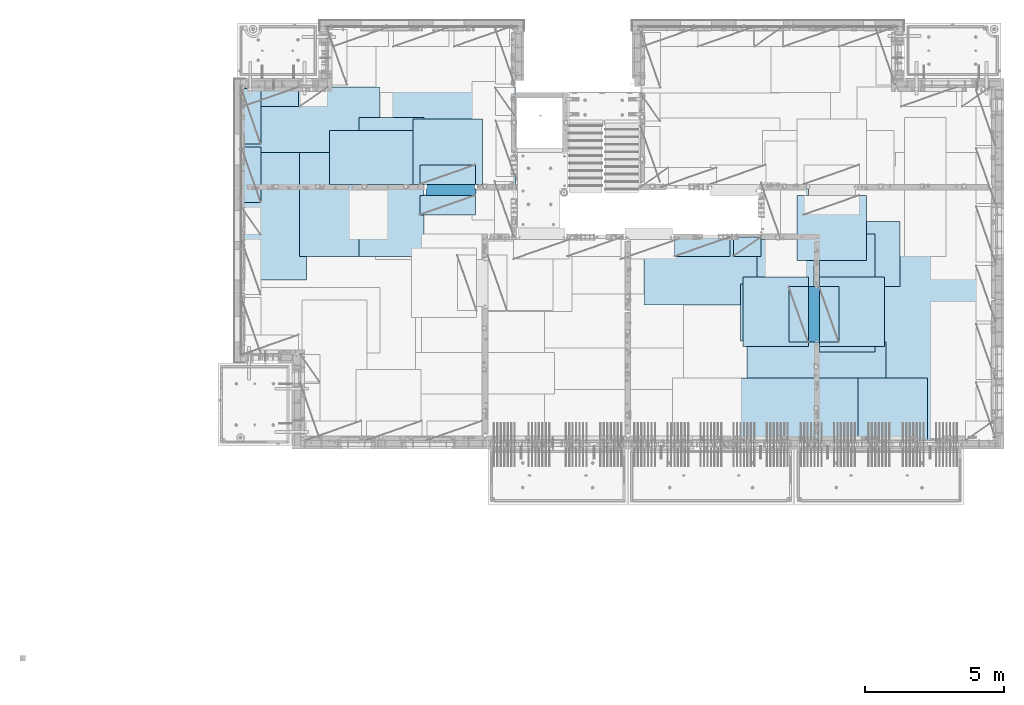
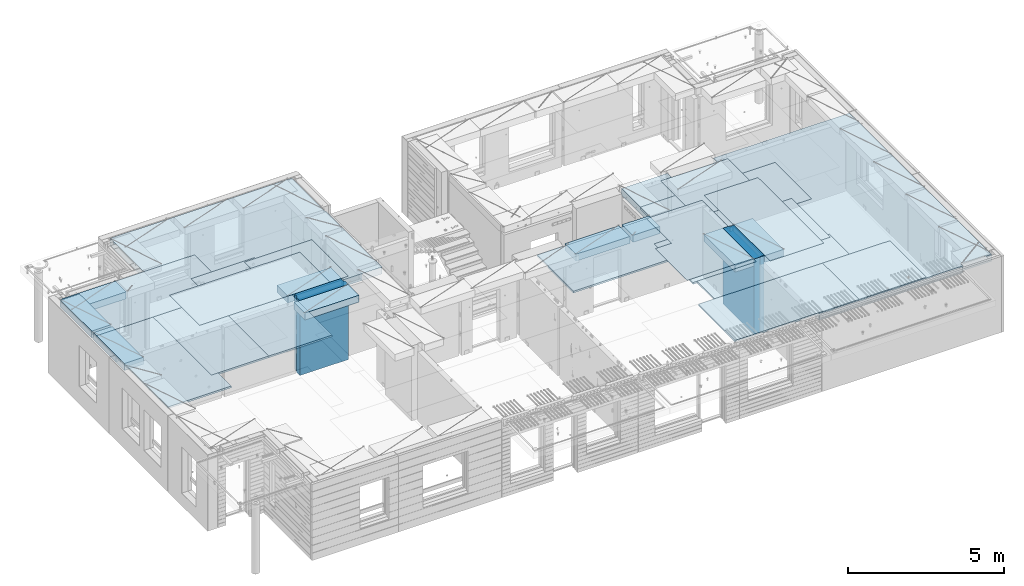
# One storey, part 197 of 334: 27 plates, 2 slabs, 25 elements without a shape of their own.
"""IFC2X3 building model written with IfcOpenShell, lengths in millimetres."""

from ifc_helpers import new_model, si_unit, frame, origin_with_axes, place, context, subcontext, project, spatial, faceted_brep, material, type_object, element, aggregate, save


model = new_model("IFC2X3")

# Units and contexts
model_context = context("Model", 3, precision=1e-05, world=origin_with_axes())
body_context = subcontext(model_context, "Body", "Model", "MODEL_VIEW")
ifc_project = project(units=[si_unit("LENGTHUNIT", "METRE", prefix="MILLI"), si_unit("AREAUNIT", "SQUARE_METRE"), si_unit("VOLUMEUNIT", "CUBIC_METRE"), si_unit("MASSUNIT", "GRAM", prefix="KILO"), si_unit("TIMEUNIT", "SECOND"), si_unit("PLANEANGLEUNIT", "RADIAN"), si_unit("SOLIDANGLEUNIT", "STERADIAN"), si_unit("THERMODYNAMICTEMPERATUREUNIT", "DEGREE_CELSIUS"), si_unit("LUMINOUSINTENSITYUNIT", "LUMEN")], contexts=[model_context])

# Site, building, storey
site_placement = place(None, origin_with_axes())
site = spatial("IfcSite", under=ifc_project, at=site_placement, CompositionType="ELEMENT")
building_placement = place(site_placement, origin_with_axes())
building = spatial("IfcBuilding", under=site, at=building_placement, CompositionType="ELEMENT")
storey_placement = place(building_placement, origin_with_axes())
storey = spatial("IfcBuildingStorey", under=building, at=storey_placement, Name="3", CompositionType="ELEMENT", Elevation=0.0)

# Assembly, slabs
assembly_1_placement = place(storey_placement, origin_with_axes())
assembly_1 = element("IfcElementAssembly", 1, at=assembly_1_placement, inside=storey, AssemblyPlace="NOTDEFINED", PredefinedType="REINFORCEMENT_UNIT")
ifc_material_1 = material(Name="CONCRETE/C30/37")
slab_type_1 = type_object("IfcSlabType", PredefinedType="NOTDEFINED")
slab_1_placement = place(assembly_1_placement, frame((7880.0, 16980.0, 90595.0), z_axis=(0.0, 1.0, 0.0), x_axis=(1.0, 0.0, 0.0)))
slab_1 = element("IfcSlab", 2, at=slab_1_placement, type_object=slab_type_1, material=ifc_material_1, PredefinedType="FLOOR", context=body_context, shape_type="Brep", body=[
    faceted_brep([(8449.99914550781, -135.0, 99.9997787475586), (8449.99914550781, 135.0, 99.9997787475586), (8449.99914550781, 135.0, 0.0), (8449.99914550781, -135.0, 0.0), (8283.68914550781, -135.0, 100.0), (8283.68914550781, 135.0, 100.0), (6583.68914550781, -135.0, 0.0), (6583.68914550781, 135.0, 0.0), (6583.68914550781, 135.0, 100.0), (6583.68914550781, -135.0, 100.0), (1.81898940354586e-12, -135.0, 1.81898940354586e-12), (1.81898940354586e-12, 135.0, 1.81898940354586e-12), (-0.0001220703125, -135.0, 3600.0), (-0.0001220703125, 135.0, 3600.0), (3110.00024414063, -135.0, 3600.0), (3110.00024414063, 135.0, 3600.0), (3110.00024414063, -135.0, 5760.0), (3110.00024414063, 135.0, 5760.0), (9850.0009765625, -135.0, 5760.0), (9850.0009765625, 135.0, 5760.0), (9850.0009765625, -135.0, 3600.0), (9850.0009765625, 135.0, 3600.0), (9870.0, -135.0, 3600.0), (9870.0, 135.0, 3600.0), (9870.0, -135.0, 0.0), (9870.0, 135.0, 0.0), (6649.99914550781, 135.0, 100.0), (6649.99914550781, -135.0, 100.0)], [[[0, 1, 2, 3]], [[4, 5, 1, 0]], [[6, 7, 8, 9]], [[10, 11, 7, 6]], [[10, 12, 13, 11]], [[12, 14, 15, 13]], [[14, 16, 17, 15]], [[16, 18, 19, 17]], [[18, 20, 21, 19]], [[20, 22, 23, 21]], [[22, 24, 25, 23]], [[25, 24, 3, 2]], [[26, 8, 7, 11, 13, 15, 17, 19, 21, 23, 25, 2, 1, 5]], [[27, 9, 8, 26, 5, 4]], [[24, 22, 20, 18, 16, 14, 12, 10, 6, 9, 27, 4, 0, 3]]]),
])
slab_type_2 = type_object("IfcSlabType", PredefinedType="NOTDEFINED")
slab_2_placement = place(assembly_1_placement, frame((28610.0, 7708.0, 90595.0), z_axis=(0.0, 1.0, 0.0), x_axis=(1.0, 0.0, 0.0)))
slab_2 = element("IfcSlab", 3, at=slab_2_placement, type_object=slab_type_2, material=ifc_material_1, PredefinedType="FLOOR", context=body_context, shape_type="Brep", body=[
    faceted_brep([(1400.0006429507, -135.0, 8972.00002930513), (1400.0006429507, 135.0, 8972.00002930513), (1385.00027673977, 135.0, 8972.00002930513), (1385.00027673977, -135.0, 8972.00002930513), (1400.0006429507, -135.0, 9230.0), (1400.0006429507, 135.0, 9230.0), (-1999.99938964844, 135.0, 9230.0), (-1999.99938964844, -135.0, 9230.0), (-299.999736057165, -135.0, 9230.0), (-299.999736057165, 135.0, 9230.0), (-1999.99938964844, -135.0, 7430.0), (-1999.99938964844, 135.0, 7430.0), (0.0, -135.0, 7430.0), (0.0, 135.0, 7430.0), (0.0, 135.0, 5722.0), (0.0, -135.0, 5722.0), (100.00089263916, 135.0, 5722.0), (100.00089263916, -135.0, 5722.0), (100.00089263916, -135.0, 5679.99963378906), (100.00089263916, 135.0, 5679.99963378906), (100.00089263916, 135.0, 3822.0), (100.00089263916, -135.0, 3822.0), (100.00089263916, 135.0, 3679.99963378906), (100.00089263916, -135.0, 3679.99963378906), (0.0, 135.0, 3679.99963378906), (0.0, -135.0, 3679.99963378906), (1.81898940354586e-12, 135.0, 1.81898940354586e-12), (1.81898940354586e-12, -135.0, 1.81898940354586e-12), (5318.0, -135.0, -8.68840288603678e-09), (5318.0, 135.0, -8.68840288603678e-09), (5318.0, -135.0, 100.0), (5318.0, 135.0, 100.0), (6449.99951171875, -135.0, 100.00023651123), (6449.99951171875, 135.0, 100.00023651123), (6449.99951171875, -135.0, 9230.0), (6449.99951171875, 135.0, 9230.0), (-300.00008947117, -135.0, 8972.00002930513), (-300.00008947117, 135.0, 8972.00002930513)], [[[0, 1, 2, 3]], [[4, 5, 1, 0]], [[6, 7, 8, 9]], [[10, 7, 6, 11]], [[12, 10, 11, 13]], [[12, 13, 14, 15]], [[15, 14, 16, 17]], [[18, 17, 16, 19, 20, 21]], [[21, 20, 22, 23]], [[23, 22, 24, 25]], [[26, 27, 25, 24]], [[28, 27, 26, 29]], [[30, 28, 29, 31]], [[32, 30, 31, 33]], [[34, 32, 33, 35]], [[3, 36, 8, 7, 10, 12, 15, 17, 18, 21, 23, 25, 27, 28, 30, 32, 34, 4, 0]], [[8, 36, 37, 9]], [[3, 2, 37, 36]], [[35, 33, 31, 29, 26, 24, 22, 20, 19, 16, 14, 13, 11, 6, 9, 37, 2, 1, 5]], [[34, 35, 5, 4]]]),
])

# Assembly, plate
assembly_2_placement = place(storey_placement, origin_with_axes())
assembly_2 = element("IfcElementAssembly", 4, at=assembly_2_placement, inside=storey, Name="Steel Assembly", AssemblyPlace="NOTDEFINED", PredefinedType="NOTDEFINED")
ifc_material_2 = material()
plate_type_1 = type_object("IfcPlateType", PredefinedType="NOTDEFINED")
plate_1_placement = place(assembly_2_placement, frame((27902.5000293051, 16680.0, 90695.1), z_axis=(1.0, 0.0, 0.0), x_axis=(0.0, -1.0, 0.0)))
plate_1 = element("IfcPlate", 5, at=plate_1_placement, type_object=plate_type_1, material=ifc_material_2, Name="1/2", context=body_context, shape_type="Brep", body=[
    faceted_brep([(0.0, -35.0, 0.0), (0.0, -35.0, 2500.0), (0.0, 35.0, 2500.0), (0.0, 35.0, 0.0), (2349.99951171875, -35.0, 2500.0), (2349.99951171875, 35.0, 2500.0), (2350.0, -35.0, 0.0), (2350.0, 35.0, 0.0)], [[[0, 1, 2, 3]], [[1, 4, 5, 2]], [[4, 6, 7, 5]], [[6, 0, 3, 7]], [[5, 7, 3, 2]], [[6, 4, 1, 0]]]),
])
aggregate(assembly_2, [plate_1])

assembly_3_placement = place(storey_placement, origin_with_axes())
assembly_3 = element("IfcElementAssembly", 6, at=assembly_3_placement, inside=storey, Name="Steel Assembly", AssemblyPlace="NOTDEFINED", PredefinedType="NOTDEFINED")
plate_2_placement = place(assembly_3_placement, frame((32610.0, 7750.0, 90695.1), z_axis=(-1.0, 3.00000001838171e-08, 0.0), x_axis=(0.0, 1.0, 0.0)))
plate_2 = element("IfcPlate", 7, at=plate_2_placement, type_object=plate_type_1, material=ifc_material_2, Name="1/2", context=body_context, shape_type="Brep", body=[
    faceted_brep([(0.0, -35.0, 0.0), (0.0, -35.0, 2500.0), (0.0, 35.0, 2500.0), (0.0, 35.0, 0.0), (2349.99951171875, -35.0, 2500.0), (2349.99951171875, 35.0, 2500.0), (2350.0, -35.0, 0.0), (2350.0, 35.0, 0.0)], [[[0, 1, 2, 3]], [[1, 4, 5, 2]], [[4, 6, 7, 5]], [[6, 0, 3, 7]], [[5, 7, 3, 2]], [[6, 4, 1, 0]]]),
])
aggregate(assembly_3, [plate_2])

assembly_4_placement = place(storey_placement, origin_with_axes())
assembly_4 = element("IfcElementAssembly", 8, at=assembly_4_placement, inside=storey, Name="Steel Assembly", AssemblyPlace="NOTDEFINED", PredefinedType="NOTDEFINED")
plate_3_placement = place(assembly_4_placement, frame((27395.0, 12730.0, 90695.1), z_axis=(-1.0, 3.00000001838171e-08, 0.0), x_axis=(0.0, 1.0, 0.0)))
plate_3 = element("IfcPlate", 9, at=plate_3_placement, type_object=plate_type_1, material=ifc_material_2, context=body_context, shape_type="Brep", body=[
    faceted_brep([(0.0, -35.0, 0.0), (0.0, -35.0, 5000.0), (0.0, 35.0, 5000.0), (0.0, 35.0, 0.0), (2349.99951171875, -35.0, 5000.0), (2349.99951171875, 35.0, 5000.0), (2350.0, -35.0, 0.0), (2350.0, 35.0, 0.0)], [[[0, 1, 2, 3]], [[1, 4, 5, 2]], [[4, 6, 7, 5]], [[6, 0, 3, 7]], [[5, 7, 3, 2]], [[6, 4, 1, 0]]]),
])
aggregate(assembly_4, [plate_3])

assembly_5_placement = place(storey_placement, origin_with_axes())
assembly_5 = element("IfcElementAssembly", 10, at=assembly_5_placement, inside=storey, Name="Steel Assembly", AssemblyPlace="NOTDEFINED", PredefinedType="NOTDEFINED")
plate_4_placement = place(assembly_5_placement, frame((28709.9995320312, 11230.0000289158, 90695.1), z_axis=(0.0, 1.0, 0.0), x_axis=(1.0, 0.0, 0.0)))
plate_4 = element("IfcPlate", 11, at=plate_4_placement, type_object=plate_type_1, material=ifc_material_2, Name="1/2", context=body_context, shape_type="Brep", body=[
    faceted_brep([(0.0, -35.0, 0.0), (0.0, -35.0, 2500.0), (0.0, 35.0, 2500.0), (0.0, 35.0, 0.0), (2349.99951171875, -35.0, 2500.0), (2349.99951171875, 35.0, 2500.0), (2350.0, -35.0, 0.0), (2350.0, 35.0, 0.0)], [[[0, 1, 2, 3]], [[1, 4, 5, 2]], [[4, 6, 7, 5]], [[6, 0, 3, 7]], [[5, 7, 3, 2]], [[6, 4, 1, 0]]]),
])
aggregate(assembly_5, [plate_4])

assembly_6_placement = place(storey_placement, origin_with_axes())
assembly_6 = element("IfcElementAssembly", 12, at=assembly_6_placement, inside=storey, Name="Steel Assembly", AssemblyPlace="NOTDEFINED", PredefinedType="NOTDEFINED")
plate_5_placement = place(assembly_6_placement, frame((25959.9995320312, 11230.0000289158, 90695.1), z_axis=(0.0, 1.0, 0.0), x_axis=(1.0, 0.0, 0.0)))
plate_5 = element("IfcPlate", 13, at=plate_5_placement, type_object=plate_type_1, material=ifc_material_2, Name="1/2", context=body_context, shape_type="Brep", body=[
    faceted_brep([(0.0, -35.0, 0.0), (0.0, -35.0, 2500.0), (0.0, 35.0, 2500.0), (0.0, 35.0, 0.0), (2349.99951171875, -35.0, 2500.0), (2349.99951171875, 35.0, 2500.0), (2350.0, -35.0, 0.0), (2350.0, 35.0, 0.0)], [[[0, 1, 2, 3]], [[1, 4, 5, 2]], [[4, 6, 7, 5]], [[6, 0, 3, 7]], [[5, 7, 3, 2]], [[6, 4, 1, 0]]]),
])
aggregate(assembly_6, [plate_5])

assembly_7_placement = place(storey_placement, origin_with_axes())
assembly_7 = element("IfcElementAssembly", 14, at=assembly_7_placement, inside=storey, Name="Steel Assembly", AssemblyPlace="NOTDEFINED", PredefinedType="NOTDEFINED")
plate_6_placement = place(assembly_7_placement, frame((7880.0, 20580.0, 90695.1), z_axis=(1.0, 0.0, 0.0), x_axis=(0.0, -1.0, 0.0)))
plate_6 = element("IfcPlate", 15, at=plate_6_placement, type_object=plate_type_1, material=ifc_material_2, context=body_context, shape_type="Brep", body=[
    faceted_brep([(0.0, -35.0, 0.0), (0.0, -35.0, 5000.0), (0.0, 35.0, 5000.0), (0.0, 35.0, 0.0), (2349.99951171875, -35.0, 5000.0), (2349.99951171875, 35.0, 5000.0), (2350.0, -35.0, 0.0), (2350.0, 35.0, 0.0)], [[[0, 1, 2, 3]], [[1, 4, 5, 2]], [[4, 6, 7, 5]], [[6, 0, 3, 7]], [[5, 7, 3, 2]], [[6, 4, 1, 0]]]),
])
aggregate(assembly_7, [plate_6])

assembly_8_placement = place(storey_placement, origin_with_axes())
assembly_8 = element("IfcElementAssembly", 16, at=assembly_8_placement, inside=storey, Name="Steel Assembly", AssemblyPlace="NOTDEFINED", PredefinedType="NOTDEFINED")
plate_7_placement = place(assembly_8_placement, frame((14063.69, 19430.0, 90695.1), z_axis=(1.0, 0.0, 0.0), x_axis=(0.0, -1.0, 0.0)))
plate_7 = element("IfcPlate", 17, at=plate_7_placement, type_object=plate_type_1, material=ifc_material_2, Name="1/2", context=body_context, shape_type="Brep", body=[
    faceted_brep([(0.0, -35.0, 0.0), (0.0, -35.0, 2500.0), (0.0, 35.0, 2500.0), (0.0, 35.0, 0.0), (2349.99951171875, -35.0, 2500.0), (2349.99951171875, 35.0, 2500.0), (2350.0, -35.0, 0.0), (2350.0, 35.0, 0.0)], [[[0, 1, 2, 3]], [[1, 4, 5, 2]], [[4, 6, 7, 5]], [[6, 0, 3, 7]], [[5, 7, 3, 2]], [[6, 4, 1, 0]]]),
])
aggregate(assembly_8, [plate_7])

assembly_9_placement = place(storey_placement, origin_with_axes())
assembly_9 = element("IfcElementAssembly", 18, at=assembly_9_placement, inside=storey, Name="Steel Assembly", AssemblyPlace="NOTDEFINED", PredefinedType="NOTDEFINED")
plate_8_placement = place(assembly_9_placement, frame((31610.0, 13388.0, 90695.1), z_axis=(-1.0, 3.00000001838171e-08, 0.0), x_axis=(0.0, 1.0, 0.0)))
plate_8 = element("IfcPlate", 19, at=plate_8_placement, type_object=plate_type_1, material=ifc_material_2, context=body_context, shape_type="Brep", body=[
    faceted_brep([(0.0, -35.0, 0.0), (0.0, -35.0, 5000.0), (0.0, 35.0, 5000.0), (0.0, 35.0, 0.0), (2349.99951171875, -35.0, 5000.0), (2349.99951171875, 35.0, 5000.0), (2350.0, -35.0, 0.0), (2350.0, 35.0, 0.0)], [[[0, 1, 2, 3]], [[1, 4, 5, 2]], [[4, 6, 7, 5]], [[6, 0, 3, 7]], [[5, 7, 3, 2]], [[6, 4, 1, 0]]]),
])
aggregate(assembly_9, [plate_8])

assembly_10_placement = place(storey_placement, origin_with_axes())
assembly_10 = element("IfcElementAssembly", 20, at=assembly_10_placement, inside=storey, Name="Steel Assembly", AssemblyPlace="NOTDEFINED", PredefinedType="NOTDEFINED")
plate_9_placement = place(assembly_10_placement, frame((31110.0, 9038.0, 90695.1), z_axis=(-1.0, 3.00000001838171e-08, 0.0), x_axis=(0.0, 1.0, 0.0)))
plate_9 = element("IfcPlate", 21, at=plate_9_placement, type_object=plate_type_1, material=ifc_material_2, context=body_context, shape_type="Brep", body=[
    faceted_brep([(0.0, -35.0, 0.0), (0.0, -35.0, 5000.0), (0.0, 35.0, 5000.0), (0.0, 35.0, 0.0), (2349.99951171875, -35.0, 5000.0), (2349.99951171875, 35.0, 5000.0), (2350.0, -35.0, 0.0), (2350.0, 35.0, 0.0)], [[[0, 1, 2, 3]], [[1, 4, 5, 2]], [[4, 6, 7, 5]], [[6, 0, 3, 7]], [[5, 7, 3, 2]], [[6, 4, 1, 0]]]),
])
aggregate(assembly_10, [plate_9])

assembly_11_placement = place(storey_placement, origin_with_axes())
assembly_11 = element("IfcElementAssembly", 22, at=assembly_11_placement, inside=storey, Name="Steel Assembly", AssemblyPlace="NOTDEFINED", PredefinedType="NOTDEFINED")
plate_10_placement = place(assembly_11_placement, frame((30510.0, 7750.0, 90695.1), z_axis=(-1.0, 3.00000001838171e-08, 0.0), x_axis=(0.0, 1.0, 0.0)))
plate_10 = element("IfcPlate", 23, at=plate_10_placement, type_object=plate_type_1, material=ifc_material_2, context=body_context, shape_type="Brep", body=[
    faceted_brep([(0.0, -35.0, 0.0), (0.0, -35.0, 5000.0), (0.0, 35.0, 5000.0), (0.0, 35.0, 0.0), (2349.99951171875, -35.0, 5000.0), (2349.99951171875, 35.0, 5000.0), (2350.0, -35.0, 0.0), (2350.0, 35.0, 0.0)], [[[0, 1, 2, 3]], [[1, 4, 5, 2]], [[4, 6, 7, 5]], [[6, 0, 3, 7]], [[5, 7, 3, 2]], [[6, 4, 1, 0]]]),
])
aggregate(assembly_11, [plate_10])

assembly_12_placement = place(storey_placement, origin_with_axes())
assembly_12 = element("IfcElementAssembly", 24, at=assembly_12_placement, inside=storey, Name="Steel Assembly", AssemblyPlace="NOTDEFINED", PredefinedType="NOTDEFINED")
plate_11_placement = place(assembly_12_placement, frame((10230.0, 18627.0, 90695.1), z_axis=(0.0, -1.0, 0.0), x_axis=(-1.0, 3.00000001838171e-08, 0.0)))
plate_11 = element("IfcPlate", 25, at=plate_11_placement, type_object=plate_type_1, material=ifc_material_2, context=body_context, shape_type="Brep", body=[
    faceted_brep([(0.0, -35.0, 0.0), (0.0, -35.0, 5000.0), (0.0, 35.0, 5000.0), (0.0, 35.0, 0.0), (2349.99951171875, -35.0, 5000.0), (2349.99951171875, 35.0, 5000.0), (2350.0, -35.0, 0.0), (2350.0, 35.0, 0.0)], [[[0, 1, 2, 3]], [[1, 4, 5, 2]], [[4, 6, 7, 5]], [[6, 0, 3, 7]], [[5, 7, 3, 2]], [[6, 4, 1, 0]]]),
])
aggregate(assembly_12, [plate_11])

assembly_13_placement = place(storey_placement, origin_with_axes())
assembly_13 = element("IfcElementAssembly", 26, at=assembly_13_placement, inside=storey, Name="Steel Assembly", AssemblyPlace="NOTDEFINED", PredefinedType="NOTDEFINED")
plate_12_placement = place(assembly_13_placement, frame((14463.69, 19480.0, 90695.1), z_axis=(0.0, -1.0, 0.0), x_axis=(-1.0, 3.00000001838171e-08, 0.0)))
plate_12 = element("IfcPlate", 27, at=plate_12_placement, type_object=plate_type_1, material=ifc_material_2, context=body_context, shape_type="Brep", body=[
    faceted_brep([(0.0, -35.0, 0.0), (0.0, -35.0, 5000.0), (0.0, 35.0, 5000.0), (0.0, 35.0, 0.0), (2349.99951171875, -35.0, 5000.0), (2349.99951171875, 35.0, 5000.0), (2350.0, -35.0, 0.0), (2350.0, 35.0, 0.0)], [[[0, 1, 2, 3]], [[1, 4, 5, 2]], [[4, 6, 7, 5]], [[6, 0, 3, 7]], [[5, 7, 3, 2]], [[6, 4, 1, 0]]]),
])
aggregate(assembly_13, [plate_12])

assembly_14_placement = place(storey_placement, origin_with_axes())
assembly_14 = element("IfcElementAssembly", 28, at=assembly_14_placement, inside=storey, Name="Steel Assembly", AssemblyPlace="NOTDEFINED", PredefinedType="NOTDEFINED")
plate_13_placement = place(assembly_14_placement, frame((12330.0, 19480.0, 90695.1), z_axis=(0.0, -1.0, 0.0), x_axis=(-1.0, 3.00000001838171e-08, 0.0)))
plate_13 = element("IfcPlate", 29, at=plate_13_placement, type_object=plate_type_1, material=ifc_material_2, context=body_context, shape_type="Brep", body=[
    faceted_brep([(0.0, -35.0, 0.0), (0.0, -35.0, 5000.0), (0.0, 35.0, 5000.0), (0.0, 35.0, 0.0), (2349.99951171875, -35.0, 5000.0), (2349.99951171875, 35.0, 5000.0), (2350.0, -35.0, 0.0), (2350.0, 35.0, 0.0)], [[[0, 1, 2, 3]], [[1, 4, 5, 2]], [[4, 6, 7, 5]], [[6, 0, 3, 7]], [[5, 7, 3, 2]], [[6, 4, 1, 0]]]),
])
aggregate(assembly_14, [plate_13])

assembly_15_placement = place(storey_placement, origin_with_axes())
assembly_15 = element("IfcElementAssembly", 30, at=assembly_15_placement, inside=storey, Name="Steel Assembly", AssemblyPlace="NOTDEFINED", PredefinedType="NOTDEFINED")
plate_type_2 = type_object("IfcPlateType", PredefinedType="NOTDEFINED")
plate_14_placement = place(assembly_15_placement, frame((7879.99987792969, 20530.0, 90595.3), z_axis=(1.0, 0.0, 0.0), x_axis=(0.0, -1.0, 0.0)))
plate_14 = element("IfcPlate", 31, at=plate_14_placement, type_object=plate_type_2, material=ifc_material_2, Name="RE1", context=body_context, shape_type="Brep", body=[
    faceted_brep([(1.81898940354586e-12, -135.0, 1.81898940354586e-12), (0.0, -135.0, 699.999999999996), (0.0, 135.0, 699.999999999996), (1.81898940354586e-12, 135.0, 1.81898940354586e-12), (1999.99951171875, -135.0, 699.999999999993), (1999.99951171875, 135.0, 699.999999999993), (2000.0, -135.0, -3.63797880709171e-12), (2000.0, 135.0, -3.63797880709171e-12)], [[[0, 1, 2, 3]], [[1, 4, 5, 2]], [[4, 6, 7, 5]], [[6, 0, 3, 7]], [[5, 7, 3, 2]], [[6, 4, 1, 0]]]),
])
aggregate(assembly_15, [plate_14])

assembly_16_placement = place(storey_placement, origin_with_axes())
assembly_16 = element("IfcElementAssembly", 32, at=assembly_16_placement, inside=storey, Name="Steel Assembly", AssemblyPlace="NOTDEFINED", PredefinedType="NOTDEFINED")
plate_15_placement = place(assembly_16_placement, frame((28710.2298779297, 13388.0, 90595.3), z_axis=(1.0, 0.0, 0.0), x_axis=(0.0, -1.0, 0.0)))
plate_15 = element("IfcPlate", 33, at=plate_15_placement, type_object=plate_type_2, material=ifc_material_2, Name="RE1", context=body_context, shape_type="Brep", body=[
    faceted_brep([(1.81898940354586e-12, -135.0, 1.81898940354586e-12), (0.0, -135.0, 699.999999999996), (0.0, 135.0, 699.999999999996), (1.81898940354586e-12, 135.0, 1.81898940354586e-12), (1999.99951171875, -135.0, 699.999999999993), (1999.99951171875, 135.0, 699.999999999993), (2000.0, -135.0, -3.63797880709171e-12), (2000.0, 135.0, -3.63797880709171e-12)], [[[0, 1, 2, 3]], [[1, 4, 5, 2]], [[4, 6, 7, 5]], [[6, 0, 3, 7]], [[5, 7, 3, 2]], [[6, 4, 1, 0]]]),
])
aggregate(assembly_16, [plate_15])

assembly_17_placement = place(storey_placement, origin_with_axes())
assembly_17 = element("IfcElementAssembly", 34, at=assembly_17_placement, inside=storey, Name="Steel Assembly", AssemblyPlace="NOTDEFINED", PredefinedType="NOTDEFINED")
plate_16_placement = place(assembly_17_placement, frame((28310.0001220703, 11388.0, 90595.3), z_axis=(-1.0, 3.00000001838171e-08, 0.0), x_axis=(0.0, 1.0, 0.0)))
plate_16 = element("IfcPlate", 35, at=plate_16_placement, type_object=plate_type_2, material=ifc_material_2, Name="RE1", context=body_context, shape_type="Brep", body=[
    faceted_brep([(1.81898940354586e-12, -135.0, 1.81898940354586e-12), (0.0, -135.0, 699.999999999996), (0.0, 135.0, 699.999999999996), (1.81898940354586e-12, 135.0, 1.81898940354586e-12), (1999.99951171875, -135.0, 699.999999999993), (1999.99951171875, 135.0, 699.999999999993), (2000.0, -135.0, -3.63797880709171e-12), (2000.0, 135.0, -3.63797880709171e-12)], [[[0, 1, 2, 3]], [[1, 4, 5, 2]], [[4, 6, 7, 5]], [[6, 0, 3, 7]], [[5, 7, 3, 2]], [[6, 4, 1, 0]]]),
])
aggregate(assembly_17, [plate_16])

assembly_18_placement = place(storey_placement, origin_with_axes())
assembly_18 = element("IfcElementAssembly", 36, at=assembly_18_placement, inside=storey, Name="Steel Assembly", AssemblyPlace="NOTDEFINED", PredefinedType="NOTDEFINED")
plate_17_placement = place(assembly_18_placement, frame((14313.6908542386, 17080.0001036336, 90595.3), z_axis=(0.0, 1.0, 0.0), x_axis=(1.0, 0.0, 0.0)))
plate_17 = element("IfcPlate", 37, at=plate_17_placement, type_object=plate_type_2, material=ifc_material_2, Name="RE1", context=body_context, shape_type="Brep", body=[
    faceted_brep([(1.81898940354586e-12, -135.0, 1.81898940354586e-12), (0.0, -135.0, 699.999999999996), (0.0, 135.0, 699.999999999996), (1.81898940354586e-12, 135.0, 1.81898940354586e-12), (1999.99951171875, -135.0, 699.999999999993), (1999.99951171875, 135.0, 699.999999999993), (2000.0, -135.0, -3.63797880709171e-12), (2000.0, 135.0, -3.63797880709171e-12)], [[[0, 1, 2, 3]], [[1, 4, 5, 2]], [[4, 6, 7, 5]], [[6, 0, 3, 7]], [[5, 7, 3, 2]], [[6, 4, 1, 0]]]),
])
aggregate(assembly_18, [plate_17])

assembly_19_placement = place(storey_placement, origin_with_axes())
assembly_19 = element("IfcElementAssembly", 38, at=assembly_19_placement, inside=storey, Name="Steel Assembly", AssemblyPlace="NOTDEFINED", PredefinedType="NOTDEFINED")
plate_18_placement = place(assembly_19_placement, frame((16313.6891457614, 16679.9998963664, 90595.3), z_axis=(0.0, -1.0, 0.0), x_axis=(-1.0, 3.00000001838171e-08, 0.0)))
plate_18 = element("IfcPlate", 39, at=plate_18_placement, type_object=plate_type_2, material=ifc_material_2, Name="RE1", context=body_context, shape_type="Brep", body=[
    faceted_brep([(1.81898940354586e-12, -135.0, 1.81898940354586e-12), (0.0, -135.0, 699.999999999996), (0.0, 135.0, 699.999999999996), (1.81898940354586e-12, 135.0, 1.81898940354586e-12), (1999.99951171875, -135.0, 699.999999999993), (1999.99951171875, 135.0, 699.999999999993), (2000.0, -135.0, -3.63797880709171e-12), (2000.0, 135.0, -3.63797880709171e-12)], [[[0, 1, 2, 3]], [[1, 4, 5, 2]], [[4, 6, 7, 5]], [[6, 0, 3, 7]], [[5, 7, 3, 2]], [[6, 4, 1, 0]]]),
])
aggregate(assembly_19, [plate_18])

assembly_20_placement = place(storey_placement, origin_with_axes())
assembly_20 = element("IfcElementAssembly", 40, at=assembly_20_placement, inside=storey, Name="Steel Assembly", AssemblyPlace="NOTDEFINED", PredefinedType="NOTDEFINED")
plate_19_placement = place(assembly_20_placement, frame((25494.9991457614, 15179.9998963664, 90595.3), z_axis=(0.0, -1.0, 0.0), x_axis=(-1.0, 3.00000001838171e-08, 0.0)))
plate_19 = element("IfcPlate", 41, at=plate_19_placement, type_object=plate_type_2, material=ifc_material_2, Name="RE1", context=body_context, shape_type="Brep", body=[
    faceted_brep([(1.81898940354586e-12, -135.0, 1.81898940354586e-12), (0.0, -135.0, 699.999999999996), (0.0, 135.0, 699.999999999996), (1.81898940354586e-12, 135.0, 1.81898940354586e-12), (1999.99951171875, -135.0, 699.999999999993), (1999.99951171875, 135.0, 699.999999999993), (2000.0, -135.0, -3.63797880709171e-12), (2000.0, 135.0, -3.63797880709171e-12)], [[[0, 1, 2, 3]], [[1, 4, 5, 2]], [[4, 6, 7, 5]], [[6, 0, 3, 7]], [[5, 7, 3, 2]], [[6, 4, 1, 0]]]),
])
aggregate(assembly_20, [plate_19])

assembly_21_placement = place(storey_placement, origin_with_axes())
assembly_21 = element("IfcElementAssembly", 42, at=assembly_21_placement, inside=storey, Name="Steel Assembly", AssemblyPlace="NOTDEFINED", PredefinedType="NOTDEFINED")
plate_20_placement = place(assembly_21_placement, frame((26610.0, 15180.0000000707, 90595.3), z_axis=(0.0, -1.0, 0.0), x_axis=(-1.0, 3.00000001838171e-08, 0.0)))
plate_20 = element("IfcPlate", 43, at=plate_20_placement, type_object=plate_type_2, material=ifc_material_2, Name="RE1_1/2", context=body_context, shape_type="Brep", body=[
    faceted_brep([(1.81898940354586e-12, -135.0, 1.81898940354586e-12), (0.0, -135.0, 699.999999999996), (0.0, 135.0, 699.999999999996), (1.81898940354586e-12, 135.0, 1.81898940354586e-12), (999.99951171875, -135.0, 700.0), (999.99951171875, 135.0, 700.0), (1000.0, -135.0, 0.0), (1000.0, 135.0, 0.0)], [[[0, 1, 2, 3]], [[1, 4, 5, 2]], [[4, 6, 7, 5]], [[6, 0, 3, 7]], [[5, 7, 3, 2]], [[6, 4, 1, 0]]]),
])
aggregate(assembly_21, [plate_20])

assembly_22_placement = place(storey_placement, origin_with_axes())
assembly_22 = element("IfcElementAssembly", 44, at=assembly_22_placement, inside=storey, Name="Steel Assembly", AssemblyPlace="NOTDEFINED", PredefinedType="NOTDEFINED")
plate_21_placement = place(assembly_22_placement, frame((9935.0, 20580.0001220703, 90595.3), z_axis=(0.0, -1.0, 0.0), x_axis=(-1.0, 3.00000001838171e-08, 0.0)))
plate_21 = element("IfcPlate", 45, at=plate_21_placement, type_object=plate_type_2, material=ifc_material_2, Name="RE1", context=body_context, shape_type="Brep", body=[
    faceted_brep([(1.81898940354586e-12, -135.0, 1.81898940354586e-12), (0.0, -135.0, 699.999999999996), (0.0, 135.0, 699.999999999996), (1.81898940354586e-12, 135.0, 1.81898940354586e-12), (1999.99951171875, -135.0, 699.999999999993), (1999.99951171875, 135.0, 699.999999999993), (2000.0, -135.0, -3.63797880709171e-12), (2000.0, 135.0, -3.63797880709171e-12)], [[[0, 1, 2, 3]], [[1, 4, 5, 2]], [[4, 6, 7, 5]], [[6, 0, 3, 7]], [[5, 7, 3, 2]], [[6, 4, 1, 0]]]),
])
aggregate(assembly_22, [plate_21])

assembly_23_placement = place(storey_placement, origin_with_axes())
assembly_23 = element("IfcElementAssembly", 46, at=assembly_23_placement, inside=storey, Name="Steel Assembly", AssemblyPlace="NOTDEFINED", PredefinedType="NOTDEFINED")
plate_22_placement = place(assembly_23_placement, frame((7879.99987792969, 18430.0, 90595.3), z_axis=(1.0, 0.0, 0.0), x_axis=(0.0, -1.0, 0.0)))
plate_22 = element("IfcPlate", 47, at=plate_22_placement, type_object=plate_type_2, material=ifc_material_2, Name="RE1", context=body_context, shape_type="Brep", body=[
    faceted_brep([(1.81898940354586e-12, -135.0, 1.81898940354586e-12), (0.0, -135.0, 699.999999999996), (0.0, 135.0, 699.999999999996), (1.81898940354586e-12, 135.0, 1.81898940354586e-12), (1999.99951171875, -135.0, 699.999999999993), (1999.99951171875, 135.0, 699.999999999993), (2000.0, -135.0, -3.63797880709171e-12), (2000.0, 135.0, -3.63797880709171e-12)], [[[0, 1, 2, 3]], [[1, 4, 5, 2]], [[4, 6, 7, 5]], [[6, 0, 3, 7]], [[5, 7, 3, 2]], [[6, 4, 1, 0]]]),
])
aggregate(assembly_23, [plate_22])

# Plate
plate_type_3 = type_object("IfcPlateType", PredefinedType="NOTDEFINED")
plate_23_placement = place(assembly_1_placement, frame((11048.0003525539, 17079.9997757405, 90725.45), z_axis=(0.0, 1.0, 0.0), x_axis=(1.0, 0.0, 0.0)))
plate_23 = element("IfcPlate", 48, at=plate_23_placement, type_object=plate_type_3, material=ifc_material_2, context=body_context, shape_type="Brep", body=[
    faceted_brep([(0.0, -5.0, 0.0), (0.0, -5.0, 1939.99963378906), (0.0, 5.0, 1939.99963378906), (0.0, 5.0, 0.0), (4827.9990234375, -5.0, 1939.99963378906), (4827.9990234375, 5.0, 1939.99963378906), (4827.9990234375, -5.0, 0.0), (4827.9990234375, 5.0, 0.0)], [[[0, 1, 2, 3]], [[1, 4, 5, 2]], [[4, 6, 7, 5]], [[6, 0, 3, 7]], [[5, 7, 3, 2]], [[6, 4, 1, 0]]]),
])

plate_type_4 = type_object("IfcPlateType", PredefinedType="NOTDEFINED")
plate_24_placement = place(assembly_1_placement, frame((28710.0010086818, 11039.9998138874, 90725.45), z_axis=(0.0, 1.0, 0.0), x_axis=(1.0, 0.0, 0.0)))
plate_24 = element("IfcPlate", 49, at=plate_24_placement, type_object=plate_type_4, material=ifc_material_2, context=body_context, shape_type="Brep", body=[
    faceted_brep([(0.0, -5.0, 0.0), (-0.00100868183653802, -5.0, 4240.0), (-0.00100868183653802, 5.0, 4240.0), (0.0, 5.0, 0.0), (2000.0, -5.0, 4240.0), (2000.0, 5.0, 4240.0), (2000.0, -5.0, 0.0), (2000.0, 5.0, 0.0)], [[[0, 1, 2, 3]], [[1, 4, 5, 2]], [[4, 6, 7, 5]], [[6, 0, 3, 7]], [[5, 7, 3, 2]], [[6, 4, 1, 0]]]),
])

plate_type_5 = type_object("IfcPlateType", PredefinedType="NOTDEFINED")
plate_25_placement = place(assembly_1_placement, frame((25860.0006272121, 11525.9998749226, 90725.45), z_axis=(1.0, 0.0, 0.0), x_axis=(0.0, -1.0, 0.0)))
plate_25 = element("IfcPlate", 50, at=plate_25_placement, type_object=plate_type_5, material=ifc_material_2, context=body_context, shape_type="Brep", body=[
    faceted_brep([(92.0000076293945, -5.0, 2449.99937278789), (92.0000076293945, 5.0, 2449.99937278789), (-1861.99975886647, 5.0, 2449.99937278789), (-1861.99975886647, -5.0, 2449.99937278789), (-1861.99975886647, -5.0, 2649.99937278789), (-1861.99975886647, 5.0, 2649.99939842034), (92.0000076293945, -5.0, 0.0), (0.0, -5.0, 0.0), (0.0, 5.0, 0.0), (92.0000076293945, 5.0, 0.0), (-1954.00048828125, -5.0, 0.0), (-1954.00048828125, 5.0, 0.0), (-1954.00048828125, -5.0, 600.000366210938), (-1954.00048828125, 5.0, 600.000366210938), (-3554.0, -5.0, 600.000366210938), (-3554.0, 5.0, 600.000366210938), (-3554.0, -5.0, 2649.99951171875), (-3554.0, 5.0, 2649.99951171875)], [[[0, 1, 2, 3]], [[4, 3, 2, 5]], [[6, 7, 8, 9]], [[7, 10, 11, 8]], [[10, 12, 13, 11]], [[12, 14, 15, 13]], [[14, 16, 17, 15]], [[17, 16, 4, 5]], [[1, 9, 8, 11, 13, 15, 17, 5, 2]], [[6, 9, 1, 0]], [[16, 14, 12, 10, 7, 6, 0, 3, 4]]]),
])

aggregate(assembly_1, [plate_24, plate_25, plate_23, slab_2, slab_1])

# Assembly, plate
assembly_24_placement = place(storey_placement, origin_with_axes())
assembly_24 = element("IfcElementAssembly", 51, at=assembly_24_placement, inside=storey, Name="Steel Assembly", AssemblyPlace="NOTDEFINED", PredefinedType="NOTDEFINED")
ifc_material_3 = material()
plate_type_6 = type_object("IfcPlateType", PredefinedType="NOTDEFINED")
plate_26_placement = place(assembly_24_placement, frame((14530.0, 16680.0, 89255.6000003815), z_axis=(0.0, 1.0, 0.0), x_axis=(1.0, 0.0, 0.0)))
plate_26 = element("IfcPlate", 52, at=plate_26_placement, type_object=plate_type_6, material=ifc_material_3, context=body_context, shape_type="Brep", body=[
    faceted_brep([(1749.99914550781, -1475.0, 400.0), (1749.99914550781, -1475.0, 243.000000000004), (1749.99914550781, 1475.0, 243.000000000004), (1749.99914550781, 1475.0, 400.0), (1799.99914550781, -1475.0, 221.333333333332), (1799.99914550781, 1475.0, 221.333333333332), (30.0, -1475.0, 400.0), (30.0, 1475.0, 400.0), (30.0, 1475.0, 243.0), (30.0, -1475.0, 243.0), (0.0, 1475.0, 230.0), (0.0, -1475.0, 230.0), (0.0, 1475.0, 0.0), (0.0, -1475.0, 0.0), (1799.99914550781, -1475.0, 3.63797880709171e-12), (1799.99914550781, 1475.0, 3.63797880709171e-12)], [[[0, 1, 2, 3]], [[4, 5, 2, 1]], [[6, 7, 8, 9]], [[9, 8, 10, 11]], [[12, 13, 11, 10]], [[14, 13, 12, 15]], [[0, 6, 9, 11, 13, 14, 4, 1]], [[7, 6, 0, 3]], [[15, 12, 10, 8, 7, 3, 2, 5]], [[14, 15, 5, 4]]]),
])
aggregate(assembly_24, [plate_26])

assembly_25_placement = place(storey_placement, origin_with_axes())
assembly_25 = element("IfcElementAssembly", 53, at=assembly_25_placement, inside=storey, Name="Steel Assembly", AssemblyPlace="NOTDEFINED", PredefinedType="NOTDEFINED")
plate_27_placement = place(assembly_25_placement, frame((28710.0, 11388.0, 89255.6000003815), z_axis=(-1.0, 3.00000001838171e-08, 0.0), x_axis=(0.0, 1.0, 0.0)))
plate_27 = element("IfcPlate", 54, at=plate_27_placement, type_object=plate_type_6, material=ifc_material_3, context=body_context, shape_type="Brep", body=[
    faceted_brep([(0.0, -1475.0, 170.000000230655), (0.0, 1475.0, 170.000000368096), (30.0, 1475.0, 156.999999999998), (30.0, -1475.0, 156.999999999998), (29.9999998430139, -1475.0, 0.0), (29.9999998430139, 1475.0, 0.0), (0.0, -1475.0, 400.0), (1999.99963378906, -1475.0, 400.0), (1999.99963378906, 1475.0, 400.0), (0.0, 1475.0, 400.0), (1999.99963378906, -1475.0, 170.000003831468), (1999.99963378906, 1475.0, 170.000003831468), (1969.99962494722, -1475.0, 157.0), (1969.99962494722, 1475.0, 157.0), (1969.99962494722, -1475.0, 0.0), (1969.99962494722, 1475.0, 0.0)], [[[0, 1, 2, 3]], [[4, 3, 2, 5]], [[6, 7, 8, 9]], [[8, 7, 10, 11]], [[12, 13, 11, 10]], [[14, 15, 13, 12]], [[15, 14, 4, 5]], [[1, 9, 8, 11, 13, 15, 5, 2]], [[6, 9, 1, 0]], [[14, 12, 10, 7, 6, 0, 3, 4]]]),
])
aggregate(assembly_25, [plate_27])

save(model, "model.ifc")
